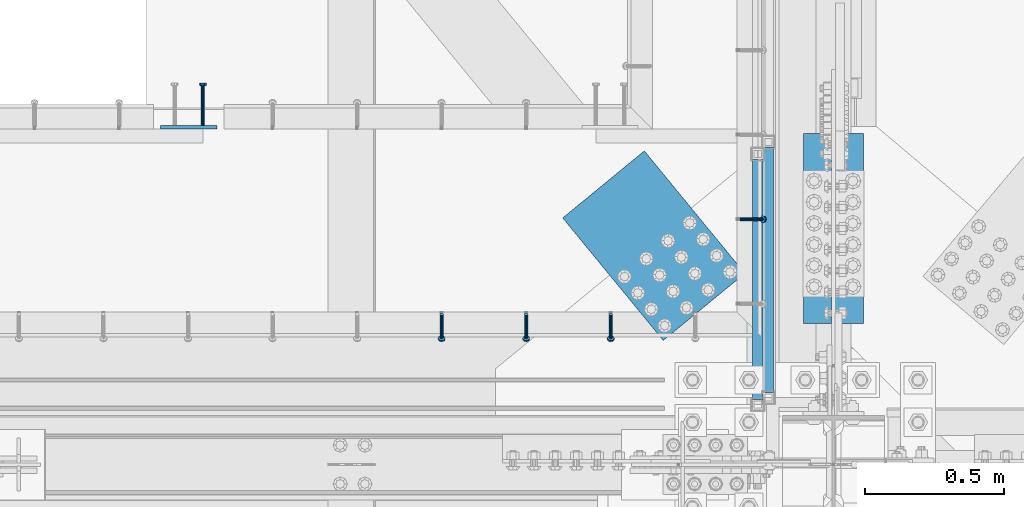
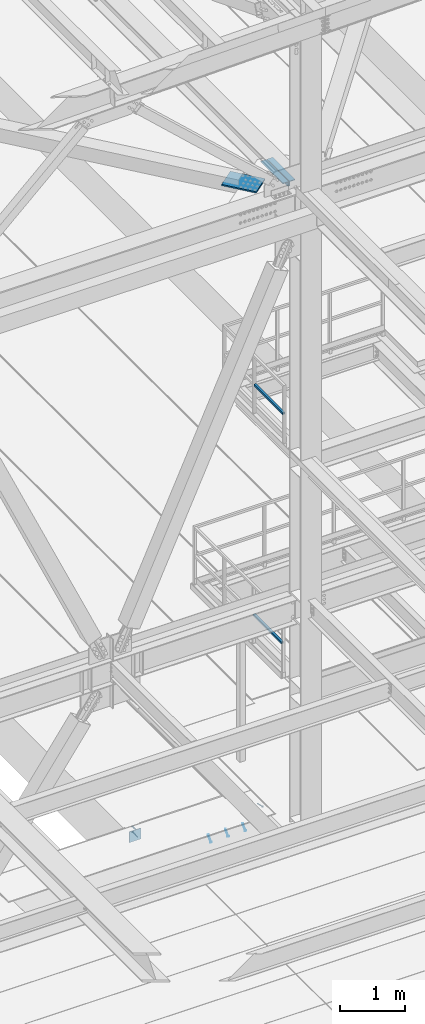
# One storey, part 2108 of 3843: 8 beams, 4 members, 8 elements without a shape of their own.
"""IFC2X3 building model written with IfcOpenShell, lengths in millimetres."""

from ifc_helpers import new_model, si_unit, frame, origin_with_axes, place, context, subcontext, project, spatial, faceted_brep, material, type_object, element, aggregate, save


model = new_model("IFC2X3")

# Units and contexts
model_context = context("Model", 3, precision=1e-05, world=origin_with_axes())
body_context = subcontext(model_context, "Body", "Model", "MODEL_VIEW")
ifc_project = project(units=[si_unit("LENGTHUNIT", "METRE", prefix="MILLI"), si_unit("AREAUNIT", "SQUARE_METRE"), si_unit("VOLUMEUNIT", "CUBIC_METRE"), si_unit("MASSUNIT", "GRAM", prefix="KILO"), si_unit("TIMEUNIT", "SECOND"), si_unit("PLANEANGLEUNIT", "RADIAN"), si_unit("SOLIDANGLEUNIT", "STERADIAN"), si_unit("THERMODYNAMICTEMPERATUREUNIT", "DEGREE_CELSIUS"), si_unit("LUMINOUSINTENSITYUNIT", "LUMEN")], contexts=[model_context])

# Site, building, storey
site_placement = place(None, origin_with_axes())
site = spatial("IfcSite", under=ifc_project, at=site_placement, CompositionType="ELEMENT")
building_placement = place(site_placement, origin_with_axes())
building = spatial("IfcBuilding", under=site, at=building_placement, Name="Undefined", CompositionType="ELEMENT")
storey_placement = place(building_placement, origin_with_axes())
storey = spatial("IfcBuildingStorey", under=building, at=storey_placement, Name="Undefined", CompositionType="ELEMENT", Elevation=0.0)

# Assembly, member
assembly_1_placement = place(storey_placement, origin_with_axes())
assembly_1 = element("IfcElementAssembly", 1, at=assembly_1_placement, inside=storey, Name="EMBED_ANGLE", AssemblyPlace="NOTDEFINED", PredefinedType="RIGID_FRAME")
ifc_material_1 = material(Name="STEEL/A108")
member_type = type_object("IfcMemberType", PredefinedType="NOTDEFINED")
member_1_placement = place(assembly_1_placement, frame((48656.0495, 26500.1375, 30446.6625), z_axis=(0.0, 1.0, 0.0), x_axis=(0.707106781186548, 0.0, -0.707106781186548)))
member_1 = element("IfcMember", 2, at=member_1_placement, type_object=member_type, material=ifc_material_1, Name="HEADED STUD ANCHOR", context=body_context, shape_type="Brep", body=[
    faceted_brep([(7.27595761418343e-12, -3.18000006675175, 5.5), (0.0, -5.49999999998363, 3.1800000667572), (118.110000000976, -5.49999999999091, 3.1800000667572), (118.110000000983, -3.18000006675175, 5.5), (0.0, -6.3499999046162, 0.0), (118.110000000968, -6.34999990461256, 0.0), (0.0, -5.49999999998363, -3.1800000667572), (118.110000000976, -5.49999999999091, -3.1800000667572), (7.27595761418343e-12, -3.18000006675175, -5.5), (118.110000000983, -3.18000006675175, -5.5), (7.27595761418343e-12, -1.81898940354586e-12, -6.34999990463257), (118.110000000968, -1.81898940354586e-12, -6.34999990463257), (0.0, 3.18000006675175, -5.5), (118.110000000968, 3.18000006674811, -5.5), (7.27595761418343e-12, 5.49999999998363, -3.1800000667572), (118.110000000983, 5.49999999998363, -3.1800000667572), (7.27595761418343e-12, 6.3499999046162, 0.0), (118.110000000976, 6.34999990461256, 0.0), (7.27595761418343e-12, 5.49999999998363, 3.1800000667572), (118.110000000983, 5.49999999998363, 3.1800000667572), (0.0, 3.18000006675175, 5.5), (118.110000000968, 3.18000006674811, 5.5), (7.27595761418343e-12, -1.81898940354586e-12, 6.34999990463257), (118.110000000968, -1.81898940354586e-12, 6.34999990463257), (120.650000000991, -10.9899997710909, 6.34999990463257), (120.650000000998, -6.34000015257152, 10.9899997711182), (120.650000000991, -12.6999998092379, 0.0), (120.650000000991, -10.9899997710909, -6.34999990463257), (120.650000000998, -6.34000015257152, -10.9899997711182), (120.650000000991, -1.81898940354586e-12, -12.6899995803833), (120.650000000991, 6.34000015257152, -10.9899997711182), (120.650000000998, 10.9899997710909, -6.34999990463257), (120.650000000991, 12.6999998092342, 0.0), (120.650000000998, 10.9899997710909, 6.34999990463257), (120.650000000991, 6.34000015257152, 10.9899997711182), (120.650000000991, -1.81898940354586e-12, 12.6899995803833), (127.000000001048, -10.9899997710945, 6.34999990463257), (127.000000001048, -6.34000015257152, 10.9899997711182), (127.000000001048, -12.6999998092342, 0.0), (127.000000001048, -10.9899997710945, -6.34999990463257), (127.000000001048, -6.34000015257152, -10.9899997711182), (127.000000001048, 1.81898940354586e-12, -12.6899995803833), (127.000000001048, 6.34000015256788, -10.9899997711182), (127.000000001048, 10.9899997710909, -6.34999990463257), (127.000000001048, 12.6999998092379, 0.0), (127.000000001048, 10.9899997710909, 6.34999990463257), (127.000000001048, 6.34000015256788, 10.9899997711182), (127.000000001048, 1.81898940354586e-12, 12.6899995803833)], [[[0, 1, 2, 3]], [[1, 4, 5, 2]], [[4, 6, 7, 5]], [[6, 8, 9, 7]], [[8, 10, 11, 9]], [[10, 12, 13, 11]], [[12, 14, 15, 13]], [[14, 16, 17, 15]], [[16, 18, 19, 17]], [[18, 20, 21, 19]], [[20, 22, 23, 21]], [[22, 0, 3, 23]], [[22, 20, 18, 16, 14, 12, 10, 8, 6, 4, 1, 0]], [[3, 2, 24, 25]], [[2, 5, 26, 24]], [[5, 7, 27, 26]], [[7, 9, 28, 27]], [[9, 11, 29, 28]], [[11, 13, 30, 29]], [[13, 15, 31, 30]], [[15, 17, 32, 31]], [[17, 19, 33, 32]], [[19, 21, 34, 33]], [[21, 23, 35, 34]], [[23, 3, 25, 35]], [[25, 24, 36, 37]], [[24, 26, 38, 36]], [[26, 27, 39, 38]], [[27, 28, 40, 39]], [[28, 29, 41, 40]], [[29, 30, 42, 41]], [[30, 31, 43, 42]], [[31, 32, 44, 43]], [[32, 33, 45, 44]], [[33, 34, 46, 45]], [[34, 35, 47, 46]], [[35, 25, 37, 47]], [[38, 39, 40, 41, 42, 43, 44, 45, 46, 47, 37, 36]]]),
])
aggregate(assembly_1, [member_1])

# Assembly, members
assembly_2_placement = place(storey_placement, origin_with_axes())
assembly_2 = element("IfcElementAssembly", 3, at=assembly_2_placement, inside=storey, Name="EMBED_ANGLE", AssemblyPlace="NOTDEFINED", PredefinedType="RIGID_FRAME")
member_2_placement = place(assembly_2_placement, frame((48193.5789921875, 26157.2374995874, 30446.6625), z_axis=(-1.0, 0.0, 0.0), x_axis=(0.0, -0.707106781186548, -0.707106781186548)))
member_2 = element("IfcMember", 4, at=member_2_placement, type_object=member_type, material=ifc_material_1, Name="HEADED STUD ANCHOR", context=body_context, shape_type="Brep", body=[
    faceted_brep([(7.27595761418343e-12, -3.18000006675175, 5.5), (0.0, -5.49999999998363, 3.1800000667572), (118.110000000976, -5.49999999999091, 3.1800000667572), (118.110000000983, -3.18000006675175, 5.5), (0.0, -6.3499999046162, 0.0), (118.110000000968, -6.34999990461256, 0.0), (0.0, -5.49999999998363, -3.1800000667572), (118.110000000976, -5.49999999999091, -3.1800000667572), (7.27595761418343e-12, -3.18000006675175, -5.5), (118.110000000983, -3.18000006675175, -5.5), (7.27595761418343e-12, -1.81898940354586e-12, -6.34999990463257), (118.110000000968, -1.81898940354586e-12, -6.34999990463257), (0.0, 3.18000006675175, -5.5), (118.110000000968, 3.18000006674811, -5.5), (7.27595761418343e-12, 5.49999999998363, -3.1800000667572), (118.110000000983, 5.49999999998363, -3.1800000667572), (7.27595761418343e-12, 6.3499999046162, 0.0), (118.110000000976, 6.34999990461256, 0.0), (7.27595761418343e-12, 5.49999999998363, 3.1800000667572), (118.110000000983, 5.49999999998363, 3.1800000667572), (0.0, 3.18000006675175, 5.5), (118.110000000968, 3.18000006674811, 5.5), (7.27595761418343e-12, -1.81898940354586e-12, 6.34999990463257), (118.110000000968, -1.81898940354586e-12, 6.34999990463257), (120.650000000991, -10.9899997710909, 6.34999990463257), (120.650000000998, -6.34000015257152, 10.9899997711182), (120.650000000991, -12.6999998092379, 0.0), (120.650000000991, -10.9899997710909, -6.34999990463257), (120.650000000998, -6.34000015257152, -10.9899997711182), (120.650000000991, -1.81898940354586e-12, -12.6899995803833), (120.650000000991, 6.34000015257152, -10.9899997711182), (120.650000000998, 10.9899997710909, -6.34999990463257), (120.650000000991, 12.6999998092342, 0.0), (120.650000000998, 10.9899997710909, 6.34999990463257), (120.650000000991, 6.34000015257152, 10.9899997711182), (120.650000000991, -1.81898940354586e-12, 12.6899995803833), (127.000000001048, -10.9899997710945, 6.34999990463257), (127.000000001048, -6.34000015257152, 10.9899997711182), (127.000000001048, -12.6999998092342, 0.0), (127.000000001048, -10.9899997710945, -6.34999990463257), (127.000000001048, -6.34000015257152, -10.9899997711182), (127.000000001048, 1.81898940354586e-12, -12.6899995803833), (127.000000001048, 6.34000015256788, -10.9899997711182), (127.000000001048, 10.9899997710909, -6.34999990463257), (127.000000001048, 12.6999998092379, 0.0), (127.000000001048, 10.9899997710909, 6.34999990463257), (127.000000001048, 6.34000015256788, 10.9899997711182), (127.000000001048, 1.81898940354586e-12, 12.6899995803833)], [[[0, 1, 2, 3]], [[1, 4, 5, 2]], [[4, 6, 7, 5]], [[6, 8, 9, 7]], [[8, 10, 11, 9]], [[10, 12, 13, 11]], [[12, 14, 15, 13]], [[14, 16, 17, 15]], [[16, 18, 19, 17]], [[18, 20, 21, 19]], [[20, 22, 23, 21]], [[22, 0, 3, 23]], [[22, 20, 18, 16, 14, 12, 10, 8, 6, 4, 1, 0]], [[3, 2, 24, 25]], [[2, 5, 26, 24]], [[5, 7, 27, 26]], [[7, 9, 28, 27]], [[9, 11, 29, 28]], [[11, 13, 30, 29]], [[13, 15, 31, 30]], [[15, 17, 32, 31]], [[17, 19, 33, 32]], [[19, 21, 34, 33]], [[21, 23, 35, 34]], [[23, 3, 25, 35]], [[25, 24, 36, 37]], [[24, 26, 38, 36]], [[26, 27, 39, 38]], [[27, 28, 40, 39]], [[28, 29, 41, 40]], [[29, 30, 42, 41]], [[30, 31, 43, 42]], [[31, 32, 44, 43]], [[32, 33, 45, 44]], [[33, 34, 46, 45]], [[34, 35, 47, 46]], [[35, 25, 37, 47]], [[38, 39, 40, 41, 42, 43, 44, 45, 46, 47, 37, 36]]]),
])
member_3_placement = place(assembly_2_placement, frame((47888.7789921875, 26157.2374995874, 30446.6625), z_axis=(-1.0, 0.0, 0.0), x_axis=(0.0, -0.707106781186548, -0.707106781186548)))
member_3 = element("IfcMember", 5, at=member_3_placement, type_object=member_type, material=ifc_material_1, Name="HEADED STUD ANCHOR", context=body_context, shape_type="Brep", body=[
    faceted_brep([(7.27595761418343e-12, -3.18000006675175, 5.5), (0.0, -5.49999999998363, 3.1800000667572), (118.110000000976, -5.49999999999091, 3.1800000667572), (118.110000000983, -3.18000006675175, 5.5), (0.0, -6.3499999046162, 0.0), (118.110000000968, -6.34999990461256, 0.0), (0.0, -5.49999999998363, -3.1800000667572), (118.110000000976, -5.49999999999091, -3.1800000667572), (7.27595761418343e-12, -3.18000006675175, -5.5), (118.110000000983, -3.18000006675175, -5.5), (7.27595761418343e-12, -1.81898940354586e-12, -6.34999990463257), (118.110000000968, -1.81898940354586e-12, -6.34999990463257), (0.0, 3.18000006675175, -5.5), (118.110000000968, 3.18000006674811, -5.5), (7.27595761418343e-12, 5.49999999998363, -3.1800000667572), (118.110000000983, 5.49999999998363, -3.1800000667572), (7.27595761418343e-12, 6.3499999046162, 0.0), (118.110000000976, 6.34999990461256, 0.0), (7.27595761418343e-12, 5.49999999998363, 3.1800000667572), (118.110000000983, 5.49999999998363, 3.1800000667572), (0.0, 3.18000006675175, 5.5), (118.110000000968, 3.18000006674811, 5.5), (7.27595761418343e-12, -1.81898940354586e-12, 6.34999990463257), (118.110000000968, -1.81898940354586e-12, 6.34999990463257), (120.650000000991, -10.9899997710909, 6.34999990463257), (120.650000000998, -6.34000015257152, 10.9899997711182), (120.650000000991, -12.6999998092379, 0.0), (120.650000000991, -10.9899997710909, -6.34999990463257), (120.650000000998, -6.34000015257152, -10.9899997711182), (120.650000000991, -1.81898940354586e-12, -12.6899995803833), (120.650000000991, 6.34000015257152, -10.9899997711182), (120.650000000998, 10.9899997710909, -6.34999990463257), (120.650000000991, 12.6999998092342, 0.0), (120.650000000998, 10.9899997710909, 6.34999990463257), (120.650000000991, 6.34000015257152, 10.9899997711182), (120.650000000991, -1.81898940354586e-12, 12.6899995803833), (127.000000001048, -10.9899997710945, 6.34999990463257), (127.000000001048, -6.34000015257152, 10.9899997711182), (127.000000001048, -12.6999998092342, 0.0), (127.000000001048, -10.9899997710945, -6.34999990463257), (127.000000001048, -6.34000015257152, -10.9899997711182), (127.000000001048, 1.81898940354586e-12, -12.6899995803833), (127.000000001048, 6.34000015256788, -10.9899997711182), (127.000000001048, 10.9899997710909, -6.34999990463257), (127.000000001048, 12.6999998092379, 0.0), (127.000000001048, 10.9899997710909, 6.34999990463257), (127.000000001048, 6.34000015256788, 10.9899997711182), (127.000000001048, 1.81898940354586e-12, 12.6899995803833)], [[[0, 1, 2, 3]], [[1, 4, 5, 2]], [[4, 6, 7, 5]], [[6, 8, 9, 7]], [[8, 10, 11, 9]], [[10, 12, 13, 11]], [[12, 14, 15, 13]], [[14, 16, 17, 15]], [[16, 18, 19, 17]], [[18, 20, 21, 19]], [[20, 22, 23, 21]], [[22, 0, 3, 23]], [[22, 20, 18, 16, 14, 12, 10, 8, 6, 4, 1, 0]], [[3, 2, 24, 25]], [[2, 5, 26, 24]], [[5, 7, 27, 26]], [[7, 9, 28, 27]], [[9, 11, 29, 28]], [[11, 13, 30, 29]], [[13, 15, 31, 30]], [[15, 17, 32, 31]], [[17, 19, 33, 32]], [[19, 21, 34, 33]], [[21, 23, 35, 34]], [[23, 3, 25, 35]], [[25, 24, 36, 37]], [[24, 26, 38, 36]], [[26, 27, 39, 38]], [[27, 28, 40, 39]], [[28, 29, 41, 40]], [[29, 30, 42, 41]], [[30, 31, 43, 42]], [[31, 32, 44, 43]], [[32, 33, 45, 44]], [[33, 34, 46, 45]], [[34, 35, 47, 46]], [[35, 25, 37, 47]], [[38, 39, 40, 41, 42, 43, 44, 45, 46, 47, 37, 36]]]),
])
member_4_placement = place(assembly_2_placement, frame((47583.9789921875, 26157.2374995874, 30446.6625), z_axis=(-1.0, 0.0, 0.0), x_axis=(0.0, -0.707106781186548, -0.707106781186548)))
member_4 = element("IfcMember", 6, at=member_4_placement, type_object=member_type, material=ifc_material_1, Name="HEADED STUD ANCHOR", context=body_context, shape_type="Brep", body=[
    faceted_brep([(7.27595761418343e-12, -3.18000006675175, 5.5), (0.0, -5.49999999998363, 3.1800000667572), (118.110000000976, -5.49999999999091, 3.1800000667572), (118.110000000983, -3.18000006675175, 5.5), (0.0, -6.3499999046162, 0.0), (118.110000000968, -6.34999990461256, 0.0), (0.0, -5.49999999998363, -3.1800000667572), (118.110000000976, -5.49999999999091, -3.1800000667572), (7.27595761418343e-12, -3.18000006675175, -5.5), (118.110000000983, -3.18000006675175, -5.5), (7.27595761418343e-12, -1.81898940354586e-12, -6.34999990463257), (118.110000000968, -1.81898940354586e-12, -6.34999990463257), (0.0, 3.18000006675175, -5.5), (118.110000000968, 3.18000006674811, -5.5), (7.27595761418343e-12, 5.49999999998363, -3.1800000667572), (118.110000000983, 5.49999999998363, -3.1800000667572), (7.27595761418343e-12, 6.3499999046162, 0.0), (118.110000000976, 6.34999990461256, 0.0), (7.27595761418343e-12, 5.49999999998363, 3.1800000667572), (118.110000000983, 5.49999999998363, 3.1800000667572), (0.0, 3.18000006675175, 5.5), (118.110000000968, 3.18000006674811, 5.5), (7.27595761418343e-12, -1.81898940354586e-12, 6.34999990463257), (118.110000000968, -1.81898940354586e-12, 6.34999990463257), (120.650000000991, -10.9899997710909, 6.34999990463257), (120.650000000998, -6.34000015257152, 10.9899997711182), (120.650000000991, -12.6999998092379, 0.0), (120.650000000991, -10.9899997710909, -6.34999990463257), (120.650000000998, -6.34000015257152, -10.9899997711182), (120.650000000991, -1.81898940354586e-12, -12.6899995803833), (120.650000000991, 6.34000015257152, -10.9899997711182), (120.650000000998, 10.9899997710909, -6.34999990463257), (120.650000000991, 12.6999998092342, 0.0), (120.650000000998, 10.9899997710909, 6.34999990463257), (120.650000000991, 6.34000015257152, 10.9899997711182), (120.650000000991, -1.81898940354586e-12, 12.6899995803833), (127.000000001048, -10.9899997710945, 6.34999990463257), (127.000000001048, -6.34000015257152, 10.9899997711182), (127.000000001048, -12.6999998092342, 0.0), (127.000000001048, -10.9899997710945, -6.34999990463257), (127.000000001048, -6.34000015257152, -10.9899997711182), (127.000000001048, 1.81898940354586e-12, -12.6899995803833), (127.000000001048, 6.34000015256788, -10.9899997711182), (127.000000001048, 10.9899997710909, -6.34999990463257), (127.000000001048, 12.6999998092379, 0.0), (127.000000001048, 10.9899997710909, 6.34999990463257), (127.000000001048, 6.34000015256788, 10.9899997711182), (127.000000001048, 1.81898940354586e-12, 12.6899995803833)], [[[0, 1, 2, 3]], [[1, 4, 5, 2]], [[4, 6, 7, 5]], [[6, 8, 9, 7]], [[8, 10, 11, 9]], [[10, 12, 13, 11]], [[12, 14, 15, 13]], [[14, 16, 17, 15]], [[16, 18, 19, 17]], [[18, 20, 21, 19]], [[20, 22, 23, 21]], [[22, 0, 3, 23]], [[22, 20, 18, 16, 14, 12, 10, 8, 6, 4, 1, 0]], [[3, 2, 24, 25]], [[2, 5, 26, 24]], [[5, 7, 27, 26]], [[7, 9, 28, 27]], [[9, 11, 29, 28]], [[11, 13, 30, 29]], [[13, 15, 31, 30]], [[15, 17, 32, 31]], [[17, 19, 33, 32]], [[19, 21, 34, 33]], [[21, 23, 35, 34]], [[23, 3, 25, 35]], [[25, 24, 36, 37]], [[24, 26, 38, 36]], [[26, 27, 39, 38]], [[27, 28, 40, 39]], [[28, 29, 41, 40]], [[29, 30, 42, 41]], [[30, 31, 43, 42]], [[31, 32, 44, 43]], [[32, 33, 45, 44]], [[33, 34, 46, 45]], [[34, 35, 47, 46]], [[35, 25, 37, 47]], [[38, 39, 40, 41, 42, 43, 44, 45, 46, 47, 37, 36]]]),
])
aggregate(assembly_2, [member_2, member_3, member_4])

# Assembly, beam
assembly_3_placement = place(storey_placement, origin_with_axes())
assembly_3 = element("IfcElementAssembly", 7, at=assembly_3_placement, inside=storey, Name="RAIL", AssemblyPlace="NOTDEFINED", PredefinedType="RIGID_FRAME")
ifc_material_2 = material()
beam_type_1 = type_object("IfcBeamType", Name="HSS1-1/2X1-1/2X1/4", PredefinedType="NOTDEFINED")
beam_1_placement = place(assembly_3_placement, frame((48761.6499877923, 26779.5373931014, 38099.9999983618), z_axis=(0.0, 0.0, 1.0), x_axis=(0.0, -1.0, 0.0)))
beam_1 = element("IfcBeam", 8, at=beam_1_placement, type_object=beam_type_1, material=ifc_material_2, Name="RAIL", ObjectType="HSS1-1/2X1-1/2X1/4", context=body_context, shape_type="Brep", body=[
    faceted_brep([(903.287393102968, -19.0500000001557, 19.0499992350015), (903.287393102968, -19.0499992350015, -19.0499992350015), (903.287393102968, 19.0499992350015, -19.0499992350015), (903.287393102968, 19.0499992350015, 19.0499992350015), (903.287393102968, -12.6999993299978, 12.6999993299978), (903.287393102968, 12.6999993299978, 12.6999993299978), (903.287393102968, 12.6999993299978, -12.6999993299978), (903.287393102968, -12.6999993299978, -12.6999993299978), (19.0499992350015, 19.0499992350015, -19.0499992350015), (19.0499992350015, 19.0499992350015, 19.0499992350015), (19.0499992350015, -19.0499992350015, 19.0499992350015), (19.0499992350015, -19.0499992350015, -19.0499992350015), (19.0499992350015, 12.6999993299978, 12.6999993299978), (19.0499992350015, -12.6999993299978, 12.6999993299978), (19.0499992350015, -12.6999993299978, -12.6999993299978), (19.0499992350015, 12.6999993299978, -12.6999993299978)], [[[0, 1, 2, 3], [4, 5, 6, 7]], [[8, 9, 3, 2]], [[9, 10, 0, 3]], [[10, 11, 1, 0]], [[11, 8, 2, 1]], [[11, 10, 9, 8], [12, 13, 14, 15]], [[14, 13, 4, 7]], [[15, 14, 7, 6]], [[12, 15, 6, 5]], [[13, 12, 5, 4]]]),
])
aggregate(assembly_3, [beam_1])

assembly_4_placement = place(storey_placement, origin_with_axes())
assembly_4 = element("IfcElementAssembly", 9, at=assembly_4_placement, inside=storey, Name="RAIL", AssemblyPlace="NOTDEFINED", PredefinedType="RIGID_FRAME")
beam_2_placement = place(assembly_4_placement, frame((48723.549999976, 26735.6166666667, 33832.8000002631), z_axis=(0.0, 0.0, 1.0), x_axis=(0.0, -1.0, 0.0)))
beam_2 = element("IfcBeam", 10, at=beam_2_placement, type_object=beam_type_1, material=ifc_material_2, Name="RAIL", ObjectType="HSS1-1/2X1-1/2X1/4", context=body_context, shape_type="Brep", body=[
    faceted_brep([(19.0499992350015, 12.6999993299978, -12.6999993299978), (19.0499992350015, -12.6999993299978, -12.6999993299978), (884.766667431661, -12.6999993299978, -12.6999993299978), (884.766667431661, 12.6999993299978, -12.6999993299978), (19.0499992350015, -12.6999993299978, 12.6999993299978), (884.766667431661, -12.6999993299978, 12.6999993299978), (19.0499992350015, 12.6999993299978, 12.6999993299978), (884.766667431661, 12.6999993299978, 12.6999993299978), (19.0499992350015, 19.0499992350015, -19.0499992350015), (19.0499992350015, 19.0499992350015, 19.0499992350015), (884.766667431661, 19.0499992350015, 19.0499992350015), (884.766667431661, 19.0499992350015, -19.0499992350015), (19.0499992350015, -19.0499992350015, 19.0499992350015), (884.766667431661, -19.0499992350015, 19.0499992350015), (19.0499992350015, -19.0499992350015, -19.0499992350015), (884.766667431661, -19.0499992350015, -19.0499992350015)], [[[0, 1, 2, 3]], [[1, 4, 5, 2]], [[4, 6, 7, 5]], [[6, 0, 3, 7]], [[8, 9, 10, 11]], [[9, 12, 13, 10]], [[12, 14, 15, 13]], [[14, 8, 11, 15]], [[13, 15, 11, 10], [5, 7, 3, 2]], [[14, 12, 9, 8], [6, 4, 1, 0]]]),
])
aggregate(assembly_4, [beam_2])

assembly_5_placement = place(storey_placement, origin_with_axes())
assembly_5 = element("IfcElementAssembly", 11, at=assembly_5_placement, inside=storey, Name="PLATE", AssemblyPlace="NOTDEFINED", PredefinedType="RIGID_FRAME")
ifc_material_3 = material(Name="STEEL/A572-50")
beam_type_2 = type_object("IfcBeamType", Name="L4X3-1/2X1/2", PredefinedType="NOTDEFINED")
beam_3_placement = place(assembly_5_placement, frame((49053.7499999825, 26123.9000000392, 42173.5250000218), z_axis=(1.0, 0.0, 0.0), x_axis=(0.0, 1.0, 0.0)))
beam_3 = element("IfcBeam", 12, at=beam_3_placement, type_object=beam_type_2, material=ifc_material_3, Name="ANGLE", ObjectType="L4X3-1/2X1/2", context=body_context, shape_type="Brep", body=[
    faceted_brep([(0.0, 44.4499999999971, -50.8000000000029), (0.0, 44.4499999999971, 50.8000000000029), (685.800000000003, 44.4499999999971, 50.8000000000029), (685.800000000003, 44.4499999999971, -50.8000000000029), (0.0, 31.75, 50.8000000000029), (685.800000000003, 31.75, 50.8000000000029), (0.0, 31.7500000838336, -38.0999999999985), (685.800000000003, 31.75, -38.0999999999985), (4.36557456851006e-11, -44.4500000000226, -38.0999999999985), (685.800000000003, -44.4499999999971, -38.0999999999985), (0.0, -44.4499999999971, -50.8000000000029), (685.800000000003, -44.4499999999971, -50.8000000000029)], [[[0, 1, 2, 3]], [[1, 4, 5, 2]], [[4, 6, 7, 5]], [[6, 8, 9, 7]], [[8, 10, 11, 9]], [[10, 0, 3, 11]], [[5, 7, 9, 11, 3, 2]], [[10, 8, 6, 4, 1, 0]]]),
])
aggregate(assembly_5, [beam_3])

assembly_6_placement = place(storey_placement, origin_with_axes())
assembly_6 = element("IfcElementAssembly", 13, at=assembly_6_placement, inside=storey, Name="PLATE", AssemblyPlace="NOTDEFINED", PredefinedType="RIGID_FRAME")
beam_4_placement = place(assembly_6_placement, frame((48939.4500000379, 26809.7000000408, 42173.5250000218), z_axis=(-1.0, 0.0, 0.0), x_axis=(0.0, -1.0, 0.0)))
beam_4 = element("IfcBeam", 14, at=beam_4_placement, type_object=beam_type_2, material=ifc_material_3, Name="ANGLE", ObjectType="L4X3-1/2X1/2", context=body_context, shape_type="Brep", body=[
    faceted_brep([(0.0, 44.4499999999971, -50.8000000000029), (0.0, 44.4499999999971, 50.8000000000029), (685.800000000003, 44.4499999999971, 50.8000000000029), (685.800000000003, 44.4499999999971, -50.8000000000029), (0.0, 31.75, 50.8000000000029), (685.800000000003, 31.75, 50.8000000000029), (0.0, 31.7500000838336, -38.0999999999985), (685.800000000003, 31.75, -38.0999999999985), (4.36557456851006e-11, -44.4500000000226, -38.0999999999985), (685.800000000003, -44.4499999999971, -38.0999999999985), (0.0, -44.4499999999971, -50.8000000000029), (685.800000000003, -44.4499999999971, -50.8000000000029)], [[[0, 1, 2, 3]], [[1, 4, 5, 2]], [[4, 6, 7, 5]], [[6, 8, 9, 7]], [[8, 10, 11, 9]], [[10, 0, 3, 11]], [[5, 7, 9, 11, 3, 2]], [[10, 8, 6, 4, 1, 0]]]),
])
aggregate(assembly_6, [beam_4])

assembly_7_placement = place(storey_placement, origin_with_axes())
assembly_7 = element("IfcElementAssembly", 15, at=assembly_7_placement, inside=storey, AssemblyPlace="NOTDEFINED", PredefinedType="RIGID_FRAME")
beam_type_3 = type_object("IfcBeamType", PredefinedType="NOTDEFINED")
beam_5_placement = place(assembly_7_placement, frame((48530.0750961041, 26184.1483771383, 42259.25), z_axis=(0.772893374461723, 0.634535918379071, 0.0), x_axis=(-0.634535918976432, 0.772893373971297, 0.0)))
beam_5 = element("IfcBeam", 16, at=beam_5_placement, type_object=beam_type_3, material=ifc_material_3, Name="PLATE", context=body_context, shape_type="Brep", body=[
    faceted_brep([(5.85714587941766e-10, 12.6999999999971, -190.500000000349), (-6.14818418398499e-10, 12.6999999999971, 190.500000000364), (571.499999996191, 12.6999999999971, 190.49999999936), (571.499999997392, 12.6999999999971, -190.500000001353), (-6.14818418398499e-10, -12.6999999999971, 190.500000000364), (571.499999996191, -12.6999999999971, 190.49999999936), (5.85714587941766e-10, -12.6999999999971, -190.500000000349), (571.499999997392, -12.6999999999971, -190.500000001353)], [[[0, 1, 2, 3]], [[1, 4, 5, 2]], [[4, 6, 7, 5]], [[6, 0, 3, 7]], [[5, 7, 3, 2]], [[6, 4, 1, 0]]]),
])
aggregate(assembly_7, [beam_5])

# Assembly, beams
assembly_8_placement = place(storey_placement, origin_with_axes())
assembly_8 = element("IfcElementAssembly", 17, at=assembly_8_placement, inside=storey, Name="EMBED PLATE", AssemblyPlace="NOTDEFINED", PredefinedType="RIGID_FRAME")
ifc_material_4 = material(Name="STEEL/A36")
beam_type_4 = type_object("IfcBeamType", PredefinedType="NOTDEFINED")
beam_6_placement = place(assembly_8_placement, frame((46672.245999992, 26831.923805746, 30445.075), z_axis=(1.0, 0.0, 0.0), x_axis=(0.0, 0.0, -1.0)))
beam_6 = element("IfcBeam", 18, at=beam_6_placement, type_object=beam_type_4, material=ifc_material_4, Name="EMBED PLATE", context=body_context, shape_type="Brep", body=[
    faceted_brep([(1.74622982740402e-10, 6.35000000000582, -101.600000000195), (-1.67347025126219e-10, 6.35000000000582, 101.600000000151), (203.200000000001, 6.35000000000582, 101.599999999999), (203.200000000001, 6.35000000000582, -101.599999999999), (-1.67347025126219e-10, -6.35000000000582, 101.600000000151), (203.200000000001, -6.35000000000582, 101.599999999999), (1.74622982740402e-10, -6.35000000000582, -101.600000000195), (203.200000000001, -6.35000000000582, -101.599999999999)], [[[0, 1, 2, 3]], [[1, 4, 5, 2]], [[4, 6, 7, 5]], [[6, 0, 3, 7]], [[5, 7, 3, 2]], [[6, 4, 1, 0]]]),
])
beam_type_5 = type_object("IfcBeamType", PredefinedType="NOTDEFINED")
beam_7_placement = place(assembly_8_placement, frame((46723.045999992, 26838.273805746, 30394.275), z_axis=(-1.0, 0.0, 0.0), x_axis=(0.0, 1.0, 0.0)))
beam_7 = element("IfcBeam", 19, at=beam_7_placement, type_object=beam_type_5, material=ifc_material_1, Name="HEADED STUD ANCHOR", context=body_context, shape_type="Brep", body=[
    faceted_brep([(7.27595761418343e-12, -3.18000006675175, 5.5), (0.0, -5.49999999998363, 3.1800000667572), (141.731999999989, -5.5, 3.1800000667572), (141.731999999989, -3.1800000667572, 5.5), (0.0, -6.3499999046162, 0.0), (141.731999999989, -6.34999990463257, 0.0), (0.0, -5.49999999998363, -3.1800000667572), (141.731999999989, -5.5, -3.1800000667572), (7.27595761418343e-12, -3.18000006675175, -5.5), (141.731999999989, -3.1800000667572, -5.5), (7.27595761418343e-12, -1.81898940354586e-12, -6.34999990463257), (141.731999999989, 0.0, -6.34999990463257), (0.0, 3.18000006675175, -5.5), (141.731999999989, 3.1800000667572, -5.5), (7.27595761418343e-12, 5.49999999998363, -3.1800000667572), (141.731999999989, 5.5, -3.1800000667572), (7.27595761418343e-12, 6.3499999046162, 0.0), (141.731999999989, 6.34999990463257, 0.0), (7.27595761418343e-12, 5.49999999998363, 3.1800000667572), (141.731999999989, 5.5, 3.1800000667572), (0.0, 3.18000006675175, 5.5), (141.731999999989, 3.1800000667572, 5.5), (7.27595761418343e-12, -1.81898940354586e-12, 6.34999990463257), (141.731999999989, 0.0, 6.34999990463257), (144.779999999999, -10.9899997711182, 6.34999990463257), (144.779999999999, -6.34000015258789, 10.9899997711182), (144.779999999999, -12.6999998092651, 0.0), (144.779999999999, -10.9899997711182, -6.34999990463257), (144.779999999999, -6.34000015258789, -10.9899997711182), (144.779999999999, 0.0, -12.6899995803833), (144.779999999999, 6.34000015258789, -10.9899997711182), (144.779999999999, 10.9899997711182, -6.34999990463257), (144.779999999999, 12.6999998092651, 0.0), (144.779999999999, 10.9899997711182, 6.34999990463257), (144.779999999999, 6.34000015258789, 10.9899997711182), (144.779999999999, 0.0, 12.6899995803833), (152.399999999994, -10.9899997711182, 6.34999990463257), (152.399999999994, -6.34000015258789, 10.9899997711182), (152.399999999994, -12.6999998092651, 0.0), (152.399999999994, -10.9899997711182, -6.34999990463257), (152.399999999994, -6.34000015258789, -10.9899997711182), (152.399999999994, 0.0, -12.6899995803833), (152.399999999994, 6.34000015258789, -10.9899997711182), (152.399999999994, 10.9899997711182, -6.34999990463257), (152.399999999994, 12.6999998092651, 0.0), (152.399999999994, 10.9899997711182, 6.34999990463257), (152.399999999994, 6.34000015258789, 10.9899997711182), (152.399999999994, 0.0, 12.6899995803833)], [[[0, 1, 2, 3]], [[1, 4, 5, 2]], [[4, 6, 7, 5]], [[6, 8, 9, 7]], [[8, 10, 11, 9]], [[10, 12, 13, 11]], [[12, 14, 15, 13]], [[14, 16, 17, 15]], [[16, 18, 19, 17]], [[18, 20, 21, 19]], [[20, 22, 23, 21]], [[22, 0, 3, 23]], [[22, 20, 18, 16, 14, 12, 10, 8, 6, 4, 1, 0]], [[3, 2, 24, 25]], [[2, 5, 26, 24]], [[5, 7, 27, 26]], [[7, 9, 28, 27]], [[9, 11, 29, 28]], [[11, 13, 30, 29]], [[13, 15, 31, 30]], [[15, 17, 32, 31]], [[17, 19, 33, 32]], [[19, 21, 34, 33]], [[21, 23, 35, 34]], [[23, 3, 25, 35]], [[25, 24, 36, 37]], [[24, 26, 38, 36]], [[26, 27, 39, 38]], [[27, 28, 40, 39]], [[28, 29, 41, 40]], [[29, 30, 42, 41]], [[30, 31, 43, 42]], [[31, 32, 44, 43]], [[32, 33, 45, 44]], [[33, 34, 46, 45]], [[34, 35, 47, 46]], [[35, 25, 37, 47]], [[38, 39, 40, 41, 42, 43, 44, 45, 46, 47, 37, 36]]]),
])
beam_8_placement = place(assembly_8_placement, frame((46723.045999992, 26838.273805746, 30292.675), z_axis=(-1.0, 0.0, 0.0), x_axis=(0.0, 1.0, 0.0)))
beam_8 = element("IfcBeam", 20, at=beam_8_placement, type_object=beam_type_5, material=ifc_material_1, Name="HEADED STUD ANCHOR", context=body_context, shape_type="Brep", body=[
    faceted_brep([(7.27595761418343e-12, -3.18000006675175, 5.5), (0.0, -5.49999999998363, 3.1800000667572), (141.731999999989, -5.5, 3.1800000667572), (141.731999999989, -3.1800000667572, 5.5), (0.0, -6.3499999046162, 0.0), (141.731999999989, -6.34999990463257, 0.0), (0.0, -5.49999999998363, -3.1800000667572), (141.731999999989, -5.5, -3.1800000667572), (7.27595761418343e-12, -3.18000006675175, -5.5), (141.731999999989, -3.1800000667572, -5.5), (7.27595761418343e-12, -1.81898940354586e-12, -6.34999990463257), (141.731999999989, 0.0, -6.34999990463257), (0.0, 3.18000006675175, -5.5), (141.731999999989, 3.1800000667572, -5.5), (7.27595761418343e-12, 5.49999999998363, -3.1800000667572), (141.731999999989, 5.5, -3.1800000667572), (7.27595761418343e-12, 6.3499999046162, 0.0), (141.731999999989, 6.34999990463257, 0.0), (7.27595761418343e-12, 5.49999999998363, 3.1800000667572), (141.731999999989, 5.5, 3.1800000667572), (0.0, 3.18000006675175, 5.5), (141.731999999989, 3.1800000667572, 5.5), (7.27595761418343e-12, -1.81898940354586e-12, 6.34999990463257), (141.731999999989, 0.0, 6.34999990463257), (144.779999999999, -10.9899997711182, 6.34999990463257), (144.779999999999, -6.34000015258789, 10.9899997711182), (144.779999999999, -12.6999998092651, 0.0), (144.779999999999, -10.9899997711182, -6.34999990463257), (144.779999999999, -6.34000015258789, -10.9899997711182), (144.779999999999, 0.0, -12.6899995803833), (144.779999999999, 6.34000015258789, -10.9899997711182), (144.779999999999, 10.9899997711182, -6.34999990463257), (144.779999999999, 12.6999998092651, 0.0), (144.779999999999, 10.9899997711182, 6.34999990463257), (144.779999999999, 6.34000015258789, 10.9899997711182), (144.779999999999, 0.0, 12.6899995803833), (152.399999999994, -10.9899997711182, 6.34999990463257), (152.399999999994, -6.34000015258789, 10.9899997711182), (152.399999999994, -12.6999998092651, 0.0), (152.399999999994, -10.9899997711182, -6.34999990463257), (152.399999999994, -6.34000015258789, -10.9899997711182), (152.399999999994, 0.0, -12.6899995803833), (152.399999999994, 6.34000015258789, -10.9899997711182), (152.399999999994, 10.9899997711182, -6.34999990463257), (152.399999999994, 12.6999998092651, 0.0), (152.399999999994, 10.9899997711182, 6.34999990463257), (152.399999999994, 6.34000015258789, 10.9899997711182), (152.399999999994, 0.0, 12.6899995803833)], [[[0, 1, 2, 3]], [[1, 4, 5, 2]], [[4, 6, 7, 5]], [[6, 8, 9, 7]], [[8, 10, 11, 9]], [[10, 12, 13, 11]], [[12, 14, 15, 13]], [[14, 16, 17, 15]], [[16, 18, 19, 17]], [[18, 20, 21, 19]], [[20, 22, 23, 21]], [[22, 0, 3, 23]], [[22, 20, 18, 16, 14, 12, 10, 8, 6, 4, 1, 0]], [[3, 2, 24, 25]], [[2, 5, 26, 24]], [[5, 7, 27, 26]], [[7, 9, 28, 27]], [[9, 11, 29, 28]], [[11, 13, 30, 29]], [[13, 15, 31, 30]], [[15, 17, 32, 31]], [[17, 19, 33, 32]], [[19, 21, 34, 33]], [[21, 23, 35, 34]], [[23, 3, 25, 35]], [[25, 24, 36, 37]], [[24, 26, 38, 36]], [[26, 27, 39, 38]], [[27, 28, 40, 39]], [[28, 29, 41, 40]], [[29, 30, 42, 41]], [[30, 31, 43, 42]], [[31, 32, 44, 43]], [[32, 33, 45, 44]], [[33, 34, 46, 45]], [[34, 35, 47, 46]], [[35, 25, 37, 47]], [[38, 39, 40, 41, 42, 43, 44, 45, 46, 47, 37, 36]]]),
])
aggregate(assembly_8, [beam_7, beam_8, beam_6])

save(model, "model.ifc")
